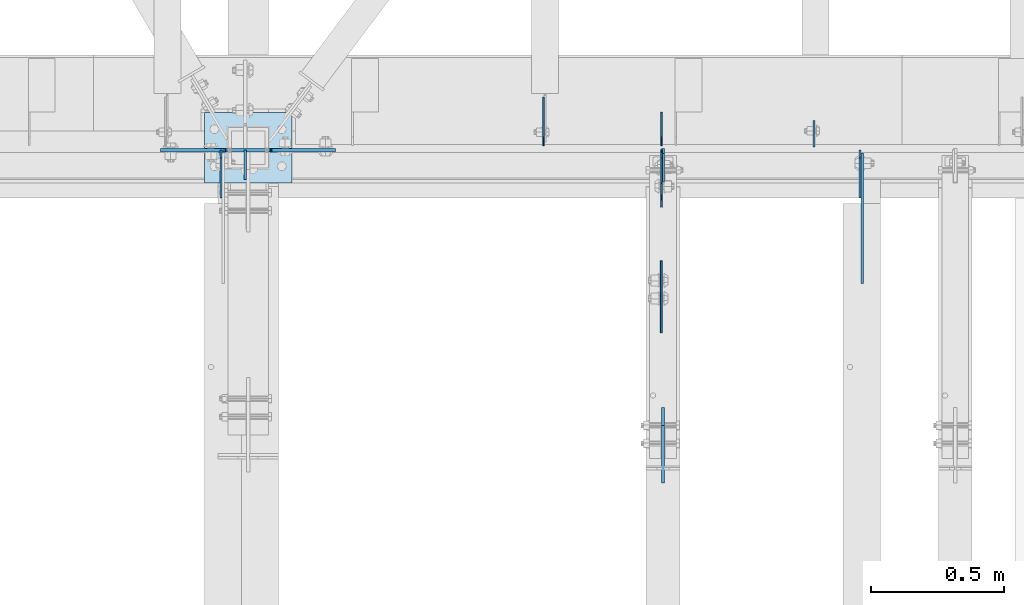
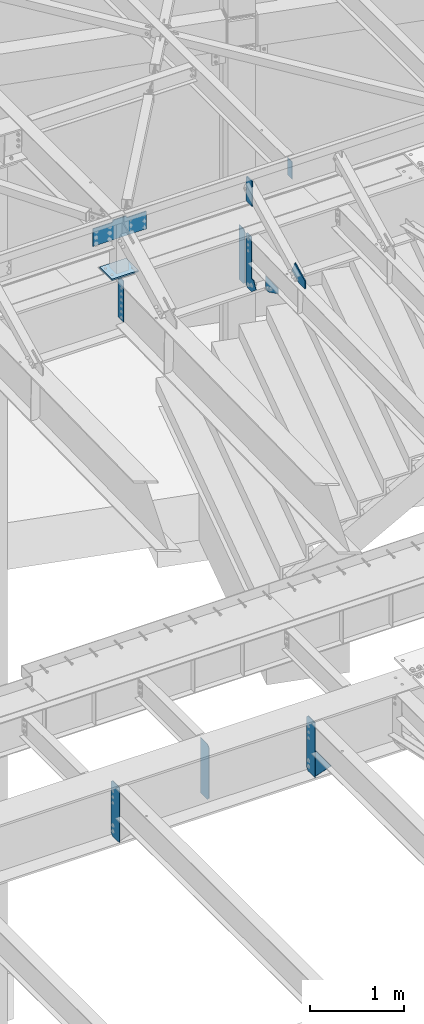
# One storey, part 1636 of 1763: 13 plates, 6 elements without a shape of their own.
"""IFC2X3 building model written with IfcOpenShell, lengths in millimetres."""

from ifc_helpers import new_model, si_unit, frame, origin_with_axes, place, context, subcontext, project, spatial, faceted_brep, material, type_object, element, aggregate, save


model = new_model("IFC2X3")

# Units and contexts
model_context = context("Model", 3, precision=1e-05, world=origin_with_axes())
body_context = subcontext(model_context, "Body", "Model", "MODEL_VIEW")
ifc_project = project(units=[si_unit("LENGTHUNIT", "METRE", prefix="MILLI"), si_unit("AREAUNIT", "SQUARE_METRE"), si_unit("VOLUMEUNIT", "CUBIC_METRE"), si_unit("MASSUNIT", "GRAM", prefix="KILO"), si_unit("TIMEUNIT", "SECOND"), si_unit("PLANEANGLEUNIT", "RADIAN"), si_unit("SOLIDANGLEUNIT", "STERADIAN"), si_unit("THERMODYNAMICTEMPERATUREUNIT", "DEGREE_CELSIUS"), si_unit("LUMINOUSINTENSITYUNIT", "LUMEN")], contexts=[model_context])

# Site, building, storey
site_placement = place(None, origin_with_axes())
site = spatial("IfcSite", under=ifc_project, at=site_placement, CompositionType="ELEMENT")
building_placement = place(site_placement, origin_with_axes())
building = spatial("IfcBuilding", under=site, at=building_placement, Name="Undefined", CompositionType="ELEMENT")
storey_placement = place(building_placement, origin_with_axes())
storey = spatial("IfcBuildingStorey", under=building, at=storey_placement, Name="Undefined", CompositionType="ELEMENT", Elevation=0.0)

# Assembly, plates
assembly_1_placement = place(storey_placement, origin_with_axes())
assembly_1 = element("IfcElementAssembly", 1, at=assembly_1_placement, inside=storey, Name="BEAM", AssemblyPlace="NOTDEFINED", PredefinedType="RIGID_FRAME")
ifc_material_1 = material(Name="STEEL/A36")
plate_type_1 = type_object("IfcPlateType", PredefinedType="NOTDEFINED")
plate_1_placement = place(assembly_1_placement, frame((-39682.6083674484, 52112.8625002127, 11682.2844061481), z_axis=(0.0, -1.0, 0.0), x_axis=(0.0, 0.0, -1.0)))
plate_1 = element("IfcPlate", 2, at=plate_1_placement, type_object=plate_type_1, material=ifc_material_1, Name="PLATE", context=body_context, shape_type="Brep", body=[
    faceted_brep([(0.0, -4.76249999999982, 0.0), (0.0, -4.76249999999709, 112.031547546387), (0.0, 4.76249999999709, 112.031547546387), (0.0, 4.76249999999982, 0.0), (533.400024414062, -4.76249999999709, 112.031547546387), (533.400024414062, 4.76249999999709, 112.031547546387), (533.400024414062, -4.76250000000073, 0.0), (533.400024414062, 4.76250000000073, 0.0)], [[[0, 1, 2, 3]], [[1, 4, 5, 2]], [[4, 6, 7, 5]], [[6, 0, 3, 7]], [[5, 7, 3, 2]], [[6, 4, 1, 0]]]),
])
plate_type_2 = type_object("IfcPlateType", PredefinedType="NOTDEFINED")
plate_2_placement = place(assembly_1_placement, frame((-38114.2385203799, 52128.7375017387, 11001.3749917698), z_axis=(0.0, 0.0, 1.0), x_axis=(0.0, 1.0, 0.0)))
plate_2 = element("IfcPlate", 3, at=plate_2_placement, type_object=plate_type_2, material=ifc_material_1, Name="PLATE", context=body_context, shape_type="Brep", body=[
    faceted_brep([(0.0, -3.17500000000291, 31.75), (0.0, -3.17500000000291, 682.625), (0.0, 3.17500000000291, 682.625), (0.0, 3.17500000000291, 31.75), (31.75, -3.17500000000291, 714.375), (31.75, 3.17500000000291, 714.375), (125.412498474121, -3.17500000000291, 714.375), (125.412498474121, 3.17500000000291, 714.375), (125.412498474121, -3.17500000000291, 0.0), (125.412498474121, 3.17500000000291, 0.0), (31.7499999999036, -3.17499999997381, 9.42916855706244e-11), (31.7499999998854, 3.17500000000291, 9.42916855706244e-11)], [[[0, 1, 2, 3]], [[1, 4, 5, 2]], [[4, 6, 7, 5]], [[6, 8, 9, 7]], [[8, 10, 11, 9]], [[10, 0, 3, 11]], [[5, 7, 9, 11, 3, 2]], [[10, 8, 6, 4, 1, 0]]]),
])

# Assembly, plate
assembly_2_placement = place(storey_placement, origin_with_axes())
assembly_2 = element("IfcElementAssembly", 4, at=assembly_2_placement, inside=storey, Name="BEAM", AssemblyPlace="NOTDEFINED", PredefinedType="RIGID_FRAME")
plate_type_3 = type_object("IfcPlateType", PredefinedType="NOTDEFINED")
plate_3_placement = place(assembly_2_placement, frame((-38107.8885203322, 50858.8358093974, 11721.3903882918), z_axis=(0.0, -0.0206852279954837, 0.999786037781472), x_axis=(0.0, 0.999786037781472, 0.0206852279954825)))
plate_3 = element("IfcPlate", 5, at=plate_3_placement, type_object=plate_type_3, material=ifc_material_1, Name="PLATE", context=body_context, shape_type="Brep", body=[
    faceted_brep([(0.0, -6.34999999999491, 1.45519152283669e-11), (1.45519152283669e-11, -6.34999999999854, 101.599998474047), (1.45519152283669e-11, 6.34999999999854, 101.599998474047), (0.0, 6.34999999999491, -2.91038304567337e-11), (218.951583862981, -6.34999999999854, 205.463943481234), (218.951583862981, 6.34999999999854, 205.463943481234), (284.27273559654, -6.34999999999854, 67.7725906370797), (284.27273559654, 6.34999999999854, 67.7725906370797), (141.413955688891, -6.34999999999854, -4.72937244921923e-11), (141.413955688891, 6.34999999999854, -4.72937244921923e-11)], [[[0, 1, 2, 3]], [[1, 4, 5, 2]], [[4, 6, 7, 5]], [[6, 8, 9, 7]], [[8, 0, 3, 9]], [[5, 7, 9, 3, 2]], [[8, 6, 4, 1, 0]]]),
])

# Assembly, plates
assembly_3_placement = place(storey_placement, origin_with_axes())
assembly_3 = element("IfcElementAssembly", 6, at=assembly_3_placement, inside=storey, Name="BEAM", AssemblyPlace="NOTDEFINED", PredefinedType="RIGID_FRAME")
plate_type_4 = type_object("IfcPlateType", PredefinedType="NOTDEFINED")
plate_4_placement = place(assembly_3_placement, frame((-38107.8885203322, 51990.6249997282, 12106.275), z_axis=(0.0, 0.0, 1.0), x_axis=(0.0, 1.0, 0.0)))
plate_4 = element("IfcPlate", 7, at=plate_4_placement, type_object=plate_type_4, material=ifc_material_1, Name="PLATE", context=body_context, shape_type="Brep", body=[
    faceted_brep([(0.0, -6.34999999999491, 1.45519152283669e-11), (0.0, -6.34999999999854, 330.200012207031), (0.0, 6.34999999999854, 330.200012207031), (0.0, 6.34999999999491, -2.91038304567337e-11), (107.950000762939, -6.34999999999854, 330.200012207031), (107.950000762939, 6.34999999999854, 330.200012207031), (127.0, -6.34999999999854, 311.150012969971), (127.0, 6.34999999999854, 311.150012969971), (127.0, -6.34999999999854, 19.0499992370605), (127.0, 6.34999999999854, 19.0499992370605), (107.950000762939, -6.34999999999854, 0.0), (107.950000762939, 6.34999999999854, 0.0)], [[[0, 1, 2, 3]], [[1, 4, 5, 2]], [[4, 6, 7, 5]], [[6, 8, 9, 7]], [[8, 10, 11, 9]], [[10, 0, 3, 11]], [[5, 7, 9, 11, 3, 2]], [[10, 8, 6, 4, 1, 0]]]),
])
plate_type_5 = type_object("IfcPlateType", PredefinedType="NOTDEFINED")
plate_5_placement = place(assembly_3_placement, frame((-37538.6896174484, 52123.9749997282, 12407.9), z_axis=(0.0, 1.0, 0.0), x_axis=(0.0, 0.0, -1.0)))
plate_5 = element("IfcPlate", 8, at=plate_5_placement, type_object=plate_type_5, material=ifc_material_1, Name="PLATE", context=body_context, shape_type="Brep", body=[
    faceted_brep([(1.81898940354586e-12, -3.17500000000291, 0.0), (-2.52839527092874e-10, -3.17500000000001, 98.4250000002357), (4.17785486206412e-08, 3.17500000000001, 98.425000000243), (-1.81898940354586e-12, 3.17499999997381, 0.0), (228.600006103516, -3.17499999999927, 98.4250030517578), (228.600006103516, 3.17499999999927, 98.4250030517578), (228.600006103516, -3.17500000001019, -7.27595761418343e-12), (228.600006103516, 3.17499999999563, -7.27595761418343e-12)], [[[0, 1, 2, 3]], [[1, 4, 5, 2]], [[4, 6, 7, 5]], [[6, 0, 3, 7]], [[5, 7, 3, 2]], [[6, 4, 1, 0]]]),
])
aggregate(assembly_3, [plate_4, plate_5])

assembly_4_placement = place(storey_placement, origin_with_axes())
assembly_4 = element("IfcElementAssembly", 9, at=assembly_4_placement, inside=storey, Name="BEAM", AssemblyPlace="NOTDEFINED", PredefinedType="RIGID_FRAME")
plate_type_6 = type_object("IfcPlateType", PredefinedType="NOTDEFINED")
plate_6_placement = place(assembly_4_placement, frame((-38559.1508154127, 52128.7375, 4448.175), z_axis=(0.0, 0.0, 1.0), x_axis=(0.0, 1.0, 0.0)))
plate_6 = element("IfcPlate", 10, at=plate_6_placement, type_object=plate_type_6, material=ifc_material_1, Name="PLATE", context=body_context, shape_type="Brep", body=[
    faceted_brep([(0.0, -3.17500000000291, 31.75), (0.0, -3.17500000000291, 687.387512207031), (0.0, 3.17500000000291, 687.387512207031), (0.0, 3.17500000000291, 31.75), (31.75, -3.17500000000291, 719.137512207031), (31.75, 3.17500000000291, 719.137512207031), (182.5625, -3.17500000000291, 719.137512207031), (182.5625, 3.17500000000291, 719.137512207031), (182.5625, -3.17500000000291, 0.0), (182.5625, 3.17500000000291, 0.0), (31.7499999999036, -3.17499999997381, 9.42916855706244e-11), (31.7499999998854, 3.17500000000291, 9.42916855706244e-11)], [[[0, 1, 2, 3]], [[1, 4, 5, 2]], [[4, 6, 7, 5]], [[6, 8, 9, 7]], [[8, 10, 11, 9]], [[10, 0, 3, 11]], [[5, 7, 9, 11, 3, 2]], [[10, 8, 6, 4, 1, 0]]]),
])
plate_type_7 = type_object("IfcPlateType", PredefinedType="NOTDEFINED")
plate_7_placement = place(assembly_4_placement, frame((-37365.7486904299, 52112.8625, 4448.175), z_axis=(0.0, 0.0, 1.0), x_axis=(0.0, -1.0, 0.0)))
plate_7 = element("IfcPlate", 11, at=plate_7_placement, type_object=plate_type_7, material=ifc_material_1, Name="PLATE", context=body_context, shape_type="Brep", body=[
    faceted_brep([(0.0, -3.96899999999732, 31.75), (0.0, -3.96899999999732, 687.387512207031), (0.0, 3.96899999999732, 687.387512207031), (0.0, 3.96899999999732, 31.75), (31.75, -3.96899999999732, 719.137512207031), (31.75, 3.96899999999732, 719.137512207031), (182.5625, -3.96899999999732, 719.137512207031), (182.5625, 3.96899999999732, 719.137512207031), (182.5625, -3.96899999999732, 0.0), (182.5625, 3.96899999999732, 0.0), (31.75, -3.96899999999732, 0.0), (31.75, 3.96899999999732, 0.0)], [[[0, 1, 2, 3]], [[1, 4, 5, 2]], [[4, 6, 7, 5]], [[6, 8, 9, 7]], [[8, 10, 11, 9]], [[10, 0, 3, 11]], [[5, 7, 9, 11, 3, 2]], [[10, 8, 6, 4, 1, 0]]]),
])
plate_8_placement = place(assembly_4_placement, frame((-39774.5153570965, 52112.8625, 4448.175), z_axis=(0.0, 0.0, 1.0), x_axis=(0.0, -1.0, 0.0)))
plate_8 = element("IfcPlate", 12, at=plate_8_placement, type_object=plate_type_7, material=ifc_material_1, Name="PLATE", context=body_context, shape_type="Brep", body=[
    faceted_brep([(0.0, -3.96899999999732, 31.75), (0.0, -3.96899999999732, 687.387512207031), (0.0, 3.96899999999732, 687.387512207031), (0.0, 3.96899999999732, 31.75), (31.75, -3.96899999999732, 719.137512207031), (31.75, 3.96899999999732, 719.137512207031), (182.5625, -3.96899999999732, 719.137512207031), (182.5625, 3.96899999999732, 719.137512207031), (182.5625, -3.96899999999732, 0.0), (182.5625, 3.96899999999732, 0.0), (31.75, -3.96899999999732, 0.0), (31.75, 3.96899999999732, 0.0)], [[[0, 1, 2, 3]], [[1, 4, 5, 2]], [[4, 6, 7, 5]], [[6, 8, 9, 7]], [[8, 10, 11, 9]], [[10, 0, 3, 11]], [[5, 7, 9, 11, 3, 2]], [[10, 8, 6, 4, 1, 0]]]),
])
aggregate(assembly_4, [plate_6, plate_7, plate_8])

# Assembly, plate
assembly_5_placement = place(storey_placement, origin_with_axes())
assembly_5 = element("IfcElementAssembly", 13, at=assembly_5_placement, inside=storey, Name="BEAM", AssemblyPlace="NOTDEFINED", PredefinedType="RIGID_FRAME")
plate_type_8 = type_object("IfcPlateType", PredefinedType="NOTDEFINED")
plate_9_placement = place(assembly_5_placement, frame((-37357.0164404127, 51930.3004272461, 4794.2499684514), z_axis=(0.0, 0.0, -1.0), x_axis=(0.0, -1.0, 0.0)))
plate_9 = element("IfcPlate", 14, at=plate_9_placement, type_object=plate_type_8, material=ifc_material_1, Name="PLATE", context=body_context, shape_type="Brep", body=[
    faceted_brep([(0.0, -4.76249999999982, 0.0), (-169.862075805664, -4.76249999999709, 6.30279828328639e-10), (-169.862075805664, 4.76249999999709, 6.30279828328639e-10), (0.0, 4.76249999999982, 0.0), (-169.862091064453, -4.76249999999709, 323.002471923828), (-169.862091064453, 4.76249999999709, 323.002471923828), (6.38101482763886e-09, -4.76249999999709, 323.002471923828), (6.38101482763886e-09, 4.76249999999709, 323.002471923828), (322.262145996094, -4.76249999999709, -1.15778675535694e-09), (322.262145996094, 4.76249999999709, -1.15778675535694e-09)], [[[0, 1, 2, 3]], [[1, 4, 5, 2]], [[4, 6, 7, 5]], [[6, 8, 9, 7]], [[8, 0, 3, 9]], [[5, 7, 9, 3, 2]], [[8, 6, 4, 1, 0]]]),
])
aggregate(assembly_5, [plate_9])

assembly_6_placement = place(storey_placement, origin_with_axes())
assembly_6 = element("IfcElementAssembly", 15, at=assembly_6_placement, inside=storey, Name="COLUMN", AssemblyPlace="NOTDEFINED", PredefinedType="RIGID_FRAME")
ifc_material_2 = material(Name="STEEL/A572-50")
plate_type_9 = type_object("IfcPlateType", PredefinedType="NOTDEFINED")
plate_10_placement = place(assembly_6_placement, frame((-39754.8396174465, 52111.2750003818, 12433.3), z_axis=(0.0, 0.0, -1.0), x_axis=(1.0, 0.0, 0.0)))
plate_10 = element("IfcPlate", 16, at=plate_10_placement, type_object=plate_type_9, material=ifc_material_2, Name="PLATE", context=body_context, shape_type="Brep", body=[
    faceted_brep([(-247.649993896484, -6.34999999999854, 25.3999996185303), (-247.649993896484, 6.34999999999854, 25.3999996185303), (-12.6999998092724, 6.34999999999854, 25.3999996185303), (-12.6999998092724, -6.34999999999854, 25.3999996185303), (-7.83992029122601, 6.34999999999854, 24.4332696959427), (-7.83992029122601, -6.34999999999854, 24.4332696959427), (-3.71974382307235, 6.34999999999854, 21.6802557954652), (-3.71974382307235, -6.34999999999854, 21.6802557954652), (-0.966729922594823, 6.34999999999854, 17.5600793273115), (-0.966729922594823, -6.34999999999854, 17.5600793273115), (-1.31614667686587e-12, -6.35, 12.6999998092651), (-1.06936913171421e-12, 6.34999923705982, 12.699999332428), (0.0, 6.34999999999491, -2.91038304567337e-11), (0.0, -6.34999999999491, 1.45519152283669e-11), (-247.649993896484, -6.34999999999854, 254.0), (412.75, -6.34999999999854, 254.0), (412.75, 6.34999999999854, 254.0), (-247.649993896484, 6.34999999999854, 254.0), (412.75, -6.34999999999854, 25.3999996185303), (412.75, 6.34999999999854, 25.3999996185303), (177.800005912781, -6.34999999999854, 25.3999996185303), (177.800005912781, 6.34999999999854, 25.3999996185303), (172.939926394734, -6.34999999999854, 24.4332696959427), (172.939926394734, 6.34999999999854, 24.4332696959427), (168.819749926581, -6.34999999999854, 21.6802557954652), (168.819749926581, 6.34999999999854, 21.6802557954652), (166.066736026103, -6.34999999999854, 17.5600793273115), (166.066736026103, 6.34999999999854, 17.5600793273115), (165.100006103516, -6.34999999999854, 12.6999998092651), (165.100006103516, 6.34999999999854, 12.6999998092651), (165.100006103516, -6.34999999999854, 0.0), (165.100006103516, 6.34999999999854, 0.0)], [[[0, 1, 2, 3]], [[3, 2, 4, 5]], [[5, 4, 6, 7]], [[7, 6, 8, 9]], [[10, 11, 12, 13]], [[9, 8, 11, 10]], [[14, 15, 16, 17]], [[15, 18, 19, 16]], [[18, 20, 21, 19]], [[20, 22, 23, 21]], [[22, 24, 25, 23]], [[24, 26, 27, 25]], [[26, 28, 29, 27]], [[28, 30, 31, 29]], [[31, 30, 13, 12]], [[6, 4, 2, 1, 17, 16, 19, 21, 23, 25, 27, 29, 31, 12, 11, 8]], [[14, 17, 1, 0]], [[30, 28, 26, 24, 22, 20, 18, 15, 14, 0, 3, 5, 7, 9, 10, 13]]]),
])

# Plate
plate_type_10 = type_object("IfcPlateType", PredefinedType="NOTDEFINED")
plate_11_placement = place(assembly_2_placement, frame((-38114.3434371258, 51694.7966838135, 11389.361387912), z_axis=(0.0, 0.0206852279954837, -0.999786037781472), x_axis=(0.0, -0.999786037781472, -0.0206852279954809)))
plate_11 = element("IfcPlate", 17, at=plate_11_placement, type_object=plate_type_10, material=ifc_material_1, Name="PLATE", context=body_context, shape_type="Brep", body=[
    faceted_brep([(1.81898940354586e-12, -3.17500000000291, 0.0), (3.65093994144991, -3.17500000000291, 176.462081909045), (3.65093994144991, 3.17500000000291, 176.462081909045), (-1.81898940354586e-12, 3.17499999997381, 0.0), (66.5735244753159, -3.17500000000291, 175.160232543794), (66.5735244753159, 3.17500000000291, 175.160232543794), (272.493255616027, -3.17500000000291, 66.8189620970425), (272.493255616027, 3.17500000000291, 66.8189620970425), (272.493255616013, -3.17500000000291, -3.03771230392158e-10), (272.493255616013, 3.17500000000291, -3.03771230392158e-10)], [[[0, 1, 2, 3]], [[1, 4, 5, 2]], [[4, 6, 7, 5]], [[6, 8, 9, 7]], [[8, 0, 3, 9]], [[5, 7, 9, 3, 2]], [[8, 6, 4, 1, 0]]]),
])

aggregate(assembly_2, [plate_3, plate_11])

plate_type_11 = type_object("IfcPlateType", PredefinedType="NOTDEFINED")
plate_12_placement = place(assembly_1_placement, frame((-38114.2385203799, 52112.8625017387, 11001.3750039768), z_axis=(0.0, 0.0, 1.0), x_axis=(0.0, -1.0, 0.0)))
plate_12 = element("IfcPlate", 18, at=plate_12_placement, type_object=plate_type_11, material=ifc_material_1, Name="PLATE", context=body_context, shape_type="Brep", body=[
    faceted_brep([(0.0, -3.17500000000291, 31.75), (0.0, -3.17500000000291, 682.625), (0.0, 3.17500000000291, 682.625), (0.0, 3.17500000000291, 31.75), (31.75, -3.17500000000291, 714.375), (31.75, 3.17500000000291, 714.375), (125.412498474121, -3.17500000000291, 714.375), (125.412498474121, 3.17500000000291, 714.375), (125.412498474121, -3.17500000000291, 170.178436279297), (125.412498474121, 3.17500000000291, 170.178436279297), (171.201705932617, -3.17500000000291, 170.178436279297), (171.201705932617, 3.17500000000291, 170.178436279297), (216.638702392578, -3.17500000000291, 79.3046722412109), (216.638702392578, 3.17500000000291, 79.3046722412109), (125.412498474121, -3.17500000000291, 0.0), (125.412498474121, 3.17500000000291, 0.0), (31.7499999999036, -3.17499999997381, 9.42916855706244e-11), (31.7499999998854, 3.17500000000291, 9.42916855706244e-11)], [[[0, 1, 2, 3]], [[1, 4, 5, 2]], [[4, 6, 7, 5]], [[6, 8, 9, 7]], [[8, 10, 11, 9]], [[10, 12, 13, 11]], [[12, 14, 15, 13]], [[14, 16, 17, 15]], [[16, 0, 3, 17]], [[5, 7, 9, 11, 13, 15, 17, 3, 2]], [[16, 14, 12, 10, 8, 6, 4, 1, 0]]]),
])

aggregate(assembly_1, [plate_2, plate_12, plate_1])

plate_type_12 = type_object("IfcPlateType", PredefinedType="NOTDEFINED")
plate_13_placement = place(assembly_6_placement, frame((-39837.3896174465, 52254.1500002138, 11757.0249917654), z_axis=(1.0, 0.0, 0.0), x_axis=(0.0, -1.0, 0.0)))
plate_13 = element("IfcPlate", 19, at=plate_13_placement, type_object=plate_type_12, material=ifc_material_1, Name="PLATE", context=body_context, shape_type="Brep", body=[
    faceted_brep([(0.0, -9.52500000000146, 0.0), (0.0, -9.52500000025611, 330.200012207846), (0.0, 9.52499999975589, 330.200012207861), (0.0, 9.52500000000146, 0.0), (266.700012207031, -9.52499999999964, 330.200012207031), (266.700012207031, 9.52499999999964, 330.200012207031), (266.700012207031, -9.52499999999964, 0.0), (266.700012207031, 9.52499999999964, 0.0)], [[[0, 1, 2, 3]], [[1, 4, 5, 2]], [[4, 6, 7, 5]], [[6, 0, 3, 7]], [[5, 7, 3, 2]], [[6, 4, 1, 0]]]),
])

aggregate(assembly_6, [plate_10, plate_13])

save(model, "model.ifc")
